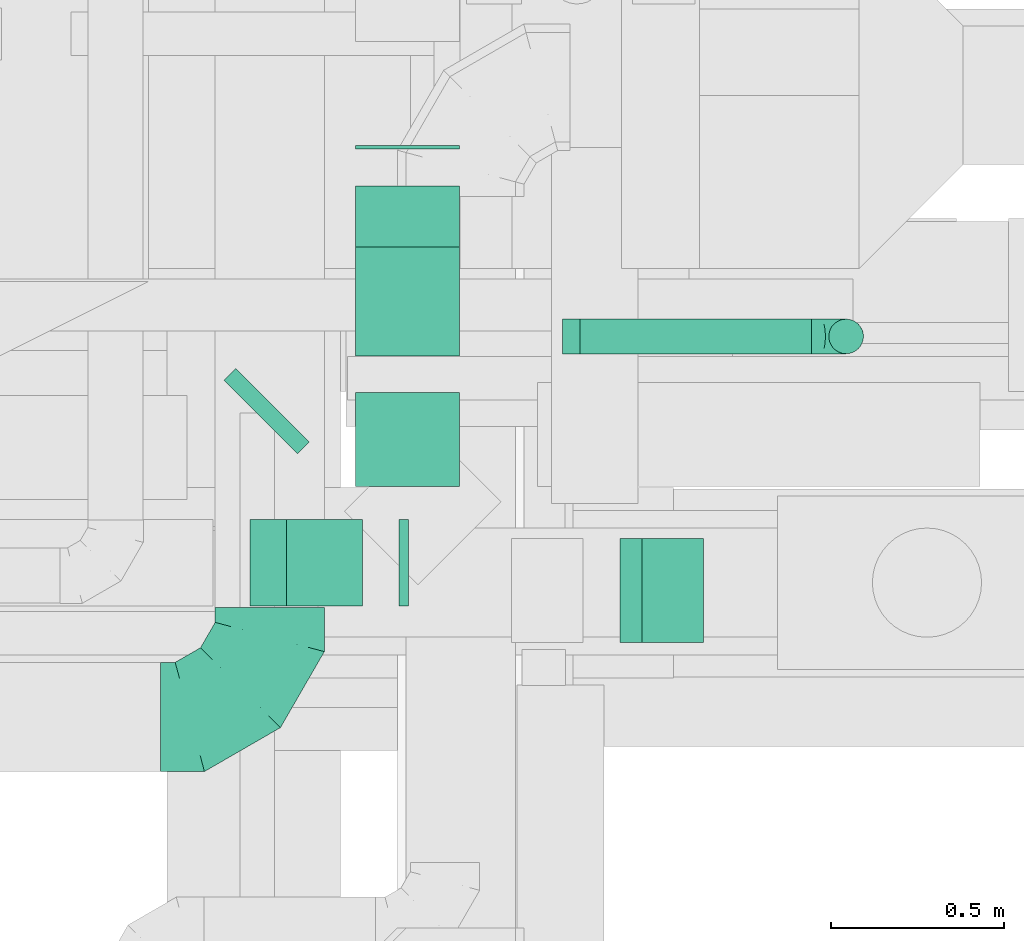
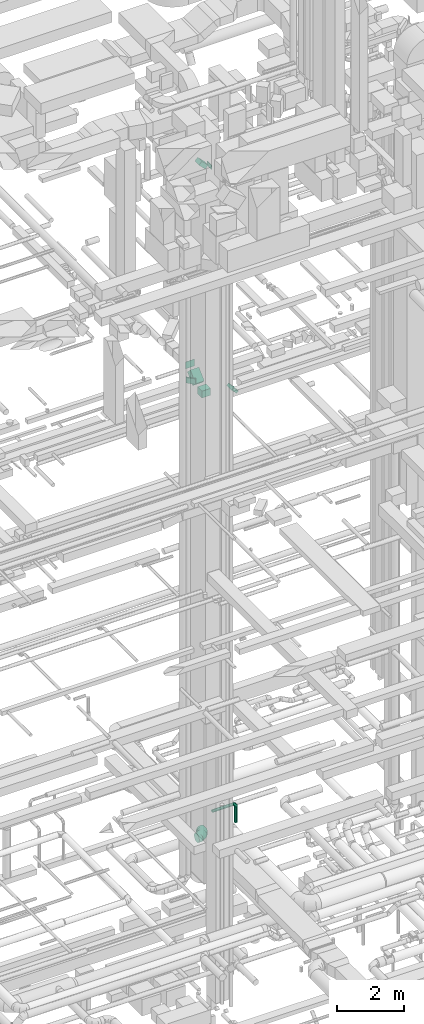
# One storey, part 191 of 337: 9 flow segments, 3 flow fittings.
"""IFC2X3 building model written with IfcOpenShell, lengths in millimetres."""

from ifc_helpers import new_model, entity, si_unit, converted_unit, derived_unit, direction, frame, frame_2d, origin, origin_2d_with_axis, place, context, subcontext, project, spatial, rectangle, circle, extrude, faceted_brep, source, transform, mapped, material, type_object, type_shapes, element, save


model = new_model("IFC2X3")

# Units and contexts
model_context = context("Model", 3, precision=0.01, world=origin(), true_north=direction((6.12303176911189e-17, 1.0)))
body_context = subcontext(model_context, "Body", "Model", "MODEL_VIEW")
ifc_project = project(units=[si_unit("LENGTHUNIT", "METRE", prefix="MILLI"), si_unit("AREAUNIT", "SQUARE_METRE"), si_unit("VOLUMEUNIT", "CUBIC_METRE"), converted_unit("PLANEANGLEUNIT", "DEGREE", entity("IfcRatioMeasure", 0.0174532925199433), si_unit("PLANEANGLEUNIT", "RADIAN"), dimensions=[0, 0, 0, 0, 0, 0, 0]), si_unit("MASSUNIT", "GRAM", prefix="KILO"), derived_unit("MASSDENSITYUNIT", [(si_unit("MASSUNIT", "GRAM", prefix="KILO"), 1), (si_unit("LENGTHUNIT", "METRE"), -3)]), derived_unit("MOMENTOFINERTIAUNIT", [(si_unit("LENGTHUNIT", "METRE"), 4)]), si_unit("TIMEUNIT", "SECOND"), si_unit("FREQUENCYUNIT", "HERTZ"), si_unit("THERMODYNAMICTEMPERATUREUNIT", "DEGREE_CELSIUS"), derived_unit("THERMALTRANSMITTANCEUNIT", [(si_unit("MASSUNIT", "GRAM", prefix="KILO"), 1), (si_unit("THERMODYNAMICTEMPERATUREUNIT", "KELVIN"), -1), (si_unit("TIMEUNIT", "SECOND"), -3)]), derived_unit("VOLUMETRICFLOWRATEUNIT", [(si_unit("LENGTHUNIT", "METRE"), 3), (si_unit("TIMEUNIT", "SECOND"), -1)]), derived_unit("MASSFLOWRATEUNIT", [(si_unit("MASSUNIT", "GRAM", prefix="KILO"), 1), (si_unit("TIMEUNIT", "SECOND"), -1)]), derived_unit("ROTATIONALFREQUENCYUNIT", [(si_unit("TIMEUNIT", "SECOND"), -1)]), si_unit("ELECTRICCURRENTUNIT", "AMPERE"), si_unit("ELECTRICVOLTAGEUNIT", "VOLT"), si_unit("POWERUNIT", "WATT"), si_unit("FORCEUNIT", "NEWTON", prefix="KILO"), si_unit("ILLUMINANCEUNIT", "LUX"), si_unit("LUMINOUSFLUXUNIT", "LUMEN"), si_unit("LUMINOUSINTENSITYUNIT", "CANDELA"), derived_unit("USERDEFINED", [(si_unit("MASSUNIT", "GRAM", prefix="KILO"), -1), (si_unit("LENGTHUNIT", "METRE"), -2), (si_unit("TIMEUNIT", "SECOND"), 3), (si_unit("LUMINOUSFLUXUNIT", "LUMEN"), 1)]), derived_unit("LINEARVELOCITYUNIT", [(si_unit("LENGTHUNIT", "METRE"), 1), (si_unit("TIMEUNIT", "SECOND"), -1)]), si_unit("PRESSUREUNIT", "PASCAL"), derived_unit("USERDEFINED", [(si_unit("LENGTHUNIT", "METRE"), -2), (si_unit("MASSUNIT", "GRAM", prefix="KILO"), 1), (si_unit("TIMEUNIT", "SECOND"), -2)]), derived_unit("LINEARFORCEUNIT", [(si_unit("MASSUNIT", "GRAM", prefix="KILO"), 1), (si_unit("LENGTHUNIT", "METRE"), 1), (si_unit("TIMEUNIT", "SECOND"), -2), (si_unit("LENGTHUNIT", "METRE"), -1)]), derived_unit("PLANARFORCEUNIT", [(si_unit("MASSUNIT", "GRAM", prefix="KILO"), 1), (si_unit("LENGTHUNIT", "METRE"), 1), (si_unit("TIMEUNIT", "SECOND"), -2), (si_unit("LENGTHUNIT", "METRE"), -2)])], contexts=[model_context])

# Site, building, storey
site_placement = place(None, origin())
site = spatial("IfcSite", under=ifc_project, at=site_placement, CompositionType="ELEMENT")
building_placement = place(site_placement, origin())
building = spatial("IfcBuilding", under=site, at=building_placement, CompositionType="ELEMENT")
storey_placement = place(building_placement, origin())
storey = spatial("IfcBuildingStorey", under=building, at=storey_placement, CompositionType="ELEMENT", Elevation=0.0)

# Flow segments
duct_segment_type_1 = type_object("IfcDuctSegmentType", PredefinedType="NOTDEFINED")
flow_segment_1_placement = place(storey_placement, frame((46619.03, 15799.14, 19100.0)))
element("IfcFlowSegment", 1, at=flow_segment_1_placement, inside=storey, type_object=duct_segment_type_1, context=body_context, shape_type="SweptSolid", body=[
    extrude(rectangle(XDim=11.0912703472507, YDim=300.000000000001, at=origin_2d_with_axis()), frame((150.0, 5.55, 0.0), z_axis=(0.0, 0.0, 1.0), x_axis=(0.0, -1.0, 0.0)), (0.0, 0.0, 1.0), 249.999999999999),
])
flow_segment_2_placement = place(storey_placement, frame((46619.03, 15202.38, 18742.16)))
element("IfcFlowSegment", 2, at=flow_segment_2_placement, inside=storey, type_object=duct_segment_type_1, context=body_context, shape_type="SweptSolid", body=[
    extrude(rectangle(XDim=250.0, YDim=300.000000000001, at=frame_2d((0.0, 0.0), x_axis=(0.0, 1.0))), frame((150.0, 88.39, 88.39), z_axis=(0.0, 0.70710678118653, 0.707106781186565), x_axis=(-1.0, 0.0, 0.0)), (0.0, 0.0, 1.0), 443.933982822071),
])
flow_segment_3_placement = place(storey_placement, frame((46619.03, 14825.32, 18625.0)))
element("IfcFlowSegment", 3, at=flow_segment_3_placement, inside=storey, type_object=duct_segment_type_1, context=body_context, shape_type="SweptSolid", body=[
    extrude(rectangle(XDim=270.994590428637, YDim=300.000000000001, at=origin_2d_with_axis()), frame((150.0, 135.5, 0.0), z_axis=(0.0, 0.0, 1.0), x_axis=(0.0, -1.0, 0.0)), (0.0, 0.0, 1.0), 249.999999999999),
])
flow_segment_4_placement = place(storey_placement, frame((47381.9, 14375.32, 18742.16)))
element("IfcFlowSegment", 4, at=flow_segment_4_placement, inside=storey, type_object=duct_segment_type_1, context=body_context, shape_type="SweptSolid", body=[
    extrude(rectangle(XDim=250.000000000009, YDim=90.3806024748539, at=frame_2d((0.0, 0.0), x_axis=(0.0, 1.0))), frame((120.34, 0.0, 120.34), z_axis=(0.0, 1.0, 0.0), x_axis=(0.707106792500133, 0.0, 0.707106769872962)), (0.0, 0.0, 1.0), 300.000000000001),
])
flow_segment_5_placement = place(storey_placement, frame((46238.96, 14920.16, 19125.02)))
element("IfcFlowSegment", 5, at=flow_segment_5_placement, inside=storey, type_object=duct_segment_type_1, context=body_context, shape_type="SweptSolid", body=[
    extrude(rectangle(XDim=48.8373029032234, YDim=300.0, at=origin_2d_with_axis()), frame((123.33, 123.33, 0.0), z_axis=(0.0, 0.0, 1.0), x_axis=(-0.707106781186082, -0.707106781187013, 0.0)), (0.0, 0.0, 1.0), 199.999999999998),
])
flow_segment_6_placement = place(storey_placement, frame((46744.63, 14481.21, 27125.0)))
element("IfcFlowSegment", 6, at=flow_segment_6_placement, inside=storey, type_object=duct_segment_type_1, context=body_context, shape_type="SweptSolid", body=[
    extrude(rectangle(XDim=26.8019484661804, YDim=249.999999999999, at=origin_2d_with_axis()), frame((13.4, 125.0, 0.0), z_axis=(0.0, 0.0, 1.0), x_axis=(-1.0, 0.0, 0.0)), (0.0, 0.0, 1.0), 150.000000000001),
])
flow_segment_7_placement = place(storey_placement, frame((46314.3, 14481.21, 27212.87)))
element("IfcFlowSegment", 7, at=flow_segment_7_placement, inside=storey, type_object=duct_segment_type_1, context=body_context, shape_type="SweptSolid", body=[
    extrude(rectangle(XDim=149.999999999987, YDim=249.999999999999, at=origin_2d_with_axis()), frame((271.23, 125.0, 53.03), z_axis=(-0.707106781186519, 0.0, 0.707106781186576), x_axis=(0.707106781186576, 0.0, 0.707106781186519)), (0.0, 0.0, 1.0), 308.578643762671),
])
duct_segment_type_2 = type_object("IfcDuctSegmentType", PredefinedType="NOTDEFINED")
flow_segment_8_placement = place(storey_placement, frame((47267.09, 15207.12, 3048.4)))
element("IfcFlowSegment", 8, at=flow_segment_8_placement, inside=storey, type_object=duct_segment_type_2, context=body_context, shape_type="SweptSolid", body=[
    extrude(circle(Radius=50.0, at=origin_2d_with_axis()), frame((0.0, 51.6, 51.6), z_axis=(1.0, 0.0, 0.0), x_axis=(0.0, -1.0, 0.0)), (0.0, 0.0, 1.0), 667.237416712188),
])
flow_segment_9_placement = place(storey_placement, frame((47982.74, 15207.12, 2420.0)))
element("IfcFlowSegment", 9, at=flow_segment_9_placement, inside=storey, type_object=duct_segment_type_2, context=body_context, shape_type="SweptSolid", body=[
    extrude(circle(Radius=50.0, at=origin_2d_with_axis()), frame((51.6, 51.6, 0.0), z_axis=(0.0, 0.0, 1.0), x_axis=(0.0, -1.0, 0.0)), (0.0, 0.0, 1.0), 580.000000000009),
])

# Flow fittings
ifc_material = material()
duct_fitting_type_1 = type_object("IfcDuctFittingType", PredefinedType="NOTDEFINED", material=ifc_material)
shared_shape_1 = source(origin(), body_context, "Body", "Brep", [
    faceted_brep([(-100.0, 0.0, -50.0), (-100.0, -12.94, -48.3), (-100.0, -25.0, -43.3), (-100.0, -35.36, -35.36), (-100.0, -43.3, -25.0), (-100.0, -48.3, -12.94), (-100.0, -50.0, 0.0), (-100.0, -48.3, 12.94), (-100.0, -43.3, 25.0), (-100.0, -35.36, 35.36), (-100.0, -25.0, 43.3), (-100.0, -12.94, 48.3), (-100.0, 0.0, 50.0), (-100.0, 12.94, 48.3), (-100.0, 25.0, 43.3), (-100.0, 35.36, 35.36), (-100.0, 43.3, 25.0), (-100.0, 48.3, 12.94), (-100.0, 50.0, 0.0), (-100.0, 48.3, -12.94), (-100.0, 43.3, -25.0), (-100.0, 35.36, -35.36), (-100.0, 25.0, -43.3), (-100.0, 12.94, -48.3), (-76.67, 12.94, 48.3), (-79.9, 25.0, 43.3), (-73.21, 0.0, 50.0), (-82.68, 35.36, 35.36), (-86.15, 48.3, 12.94), (-86.6, 50.0, 0.0), (-84.81, 43.3, 25.0), (-84.81, 43.3, -25.0), (-82.68, 35.36, -35.36), (-86.15, 48.3, -12.94), (-76.67, 12.94, -48.3), (-73.21, 0.0, -50.0), (-79.9, 25.0, -43.3), (-69.74, -12.94, -48.3), (-66.51, -25.0, -43.3), (-63.73, -35.36, -35.36), (-61.6, -43.3, -25.0), (-60.26, -48.3, -12.94), (-59.81, -50.0, 0.0), (-60.26, -48.3, 12.94), (-61.6, -43.3, 25.0), (-63.73, -35.36, 35.36), (-66.51, -25.0, 43.3), (-69.74, -12.94, 48.3), (-36.27, 36.27, 48.3), (-45.1, 45.1, 43.3), (-26.79, 26.79, 50.0), (-52.68, 52.68, 35.36), (-58.49, 58.49, 25.0), (-62.15, 62.15, 12.94), (-63.4, 63.4, 0.0), (-62.15, 62.15, -12.94), (-58.49, 58.49, -25.0), (-52.68, 52.68, -35.36), (-36.27, 36.27, -48.3), (-26.79, 26.79, -50.0), (-45.1, 45.1, -43.3), (-17.32, 17.32, -48.3), (-8.49, 8.49, -43.3), (-0.91, 0.91, -35.36), (4.9, -4.9, -25.0), (8.56, -8.56, -12.94), (9.81, -9.81, 0.0), (8.56, -8.56, 12.94), (4.9, -4.9, 25.0), (-0.91, 0.91, 35.36), (-8.49, 8.49, 43.3), (-17.32, 17.32, 48.3), (-12.94, 76.67, 48.3), (-25.0, 79.9, 43.3), (0.0, 73.21, 50.0), (-35.36, 82.68, 35.36), (-43.3, 84.81, 25.0), (-48.3, 86.15, 12.94), (-50.0, 86.6, 0.0), (-48.3, 86.15, -12.94), (-43.3, 84.81, -25.0), (-35.36, 82.68, -35.36), (-12.94, 76.67, -48.3), (0.0, 73.21, -50.0), (-25.0, 79.9, -43.3), (12.94, 69.74, -48.3), (25.0, 66.51, -43.3), (35.36, 63.73, -35.36), (43.3, 61.6, -25.0), (48.3, 60.26, -12.94), (50.0, 59.81, 0.0), (48.3, 60.26, 12.94), (43.3, 61.6, 25.0), (35.36, 63.73, 35.36), (25.0, 66.51, 43.3), (12.94, 69.74, 48.3), (-12.94, 100.0, -48.3), (-25.0, 100.0, -43.3), (-35.36, 100.0, -35.36), (-43.3, 100.0, -25.0), (-48.3, 100.0, -12.94), (-50.0, 100.0, 0.0), (-48.3, 100.0, 12.94), (-43.3, 100.0, 25.0), (-35.36, 100.0, 35.36), (-25.0, 100.0, 43.3), (-12.94, 100.0, 48.3), (0.0, 100.0, 50.0), (12.94, 100.0, 48.3), (25.0, 100.0, 43.3), (35.36, 100.0, 35.36), (43.3, 100.0, 25.0), (48.3, 100.0, 12.94), (50.0, 100.0, 0.0), (48.3, 100.0, -12.94), (43.3, 100.0, -25.0), (35.36, 100.0, -35.36), (25.0, 100.0, -43.3), (12.94, 100.0, -48.3), (0.0, 100.0, -50.0)], [[[0, 1, 2, 3, 4, 5, 6, 7, 8, 9, 10, 11, 12, 13, 14, 15, 16, 17, 18, 19, 20, 21, 22, 23]], [[24, 25, 14, 13]], [[26, 24, 13, 12]], [[14, 25, 27, 15]], [[28, 29, 18, 17]], [[30, 28, 17, 16]], [[15, 27, 30, 16]], [[20, 31, 32, 21]], [[33, 31, 20, 19]], [[18, 29, 33, 19]], [[34, 35, 0, 23]], [[36, 34, 23, 22]], [[32, 36, 22, 21]], [[2, 1, 37, 38]], [[3, 2, 38, 39]], [[0, 35, 37, 1]], [[5, 4, 40, 41]], [[6, 5, 41, 42]], [[3, 39, 40, 4]], [[6, 42, 43, 7]], [[7, 43, 44, 8]], [[8, 44, 45, 9]], [[10, 46, 47, 11]], [[11, 47, 26, 12]], [[10, 9, 45, 46]], [[48, 49, 25, 24]], [[50, 48, 24, 26]], [[27, 25, 49, 51]], [[52, 53, 28, 30]], [[51, 52, 30, 27]], [[29, 28, 53, 54]], [[55, 56, 31, 33]], [[54, 55, 33, 29]], [[57, 32, 31, 56]], [[58, 59, 35, 34]], [[60, 58, 34, 36]], [[57, 60, 36, 32]], [[37, 35, 59, 61]], [[38, 37, 61, 62]], [[39, 38, 62, 63]], [[41, 40, 64, 65]], [[42, 41, 65, 66]], [[63, 64, 40, 39]], [[43, 42, 66, 67]], [[44, 43, 67, 68]], [[68, 69, 45, 44]], [[46, 45, 69, 70]], [[47, 46, 70, 71]], [[26, 47, 71, 50]], [[72, 73, 49, 48]], [[74, 72, 48, 50]], [[51, 49, 73, 75]], [[76, 77, 53, 52]], [[75, 76, 52, 51]], [[54, 53, 77, 78]], [[79, 80, 56, 55]], [[78, 79, 55, 54]], [[81, 57, 56, 80]], [[82, 83, 59, 58]], [[84, 82, 58, 60]], [[81, 84, 60, 57]], [[61, 59, 83, 85]], [[62, 61, 85, 86]], [[63, 62, 86, 87]], [[65, 64, 88, 89]], [[66, 65, 89, 90]], [[87, 88, 64, 63]], [[67, 66, 90, 91]], [[68, 67, 91, 92]], [[92, 93, 69, 68]], [[70, 69, 93, 94]], [[71, 70, 94, 95]], [[50, 71, 95, 74]], [[96, 97, 98, 99, 100, 101, 102, 103, 104, 105, 106, 107, 108, 109, 110, 111, 112, 113, 114, 115, 116, 117, 118, 119]], [[72, 74, 107, 106]], [[73, 72, 106, 105]], [[75, 73, 105, 104]], [[77, 76, 103, 102]], [[78, 77, 102, 101]], [[75, 104, 103, 76]], [[78, 101, 100, 79]], [[79, 100, 99, 80]], [[80, 99, 98, 81]], [[96, 119, 83, 82]], [[97, 96, 82, 84]], [[84, 81, 98, 97]], [[83, 119, 118, 85]], [[85, 118, 117, 86]], [[86, 117, 116, 87]], [[88, 115, 114, 89]], [[89, 114, 113, 90]], [[87, 116, 115, 88]], [[91, 90, 113, 112]], [[92, 91, 112, 111]], [[93, 92, 111, 110]], [[95, 94, 109, 108]], [[74, 95, 108, 107]], [[110, 109, 94, 93]]]),
])
type_shapes(duct_fitting_type_1, [shared_shape_1])
flow_fitting_1_placement = place(storey_placement, frame((48034.33, 15258.71, 3100.0), z_axis=(0.0, 1.0, 0.0), x_axis=(1.0, 0.0, 0.0)))
element("IfcFlowFitting", 10, at=flow_fitting_1_placement, inside=storey, type_object=duct_fitting_type_1, material=ifc_material, context=body_context, shape_type="MappedRepresentation", body=[
    mapped(shared_shape_1, transform((0.0, 0.0, 0.0), scale=1.0)),
])
duct_fitting_type_2 = type_object("IfcDuctFittingType", PredefinedType="NOTDEFINED", material=ifc_material)
shared_shape_2 = source(origin(), body_context, "Body", "Brep", [
    faceted_brep([(-315.0, 0.0, -157.5), (-315.0, -40.76, -152.13), (-315.0, -78.75, -136.4), (-315.0, -111.37, -111.37), (-315.0, -136.4, -78.75), (-315.0, -152.13, -40.76), (-315.0, -157.5, 0.0), (-315.0, -152.13, 40.76), (-315.0, -136.4, 78.75), (-315.0, -111.37, 111.37), (-315.0, -78.75, 136.4), (-315.0, -40.76, 152.13), (-315.0, 0.0, 157.5), (-315.0, 40.76, 152.13), (-315.0, 78.75, 136.4), (-315.0, 111.37, 111.37), (-315.0, 136.4, 78.75), (-315.0, 152.13, 40.76), (-315.0, 157.5, 0.0), (-315.0, 152.13, -40.76), (-315.0, 136.4, -78.75), (-315.0, 111.37, -111.37), (-315.0, 78.75, -136.4), (-315.0, 40.76, -152.13), (-241.52, 40.76, 152.13), (-251.7, 78.75, 136.4), (-230.6, 0.0, 157.5), (-260.44, 111.37, 111.37), (-271.36, 152.13, 40.76), (-272.8, 157.5, 0.0), (-267.14, 136.4, 78.75), (-267.14, 136.4, -78.75), (-260.44, 111.37, -111.37), (-271.36, 152.13, -40.76), (-241.52, 40.76, -152.13), (-230.6, 0.0, -157.5), (-251.7, 78.75, -136.4), (-219.67, -40.76, -152.13), (-209.5, -78.75, -136.4), (-200.75, -111.37, -111.37), (-194.05, -136.4, -78.75), (-189.83, -152.13, -40.76), (-188.39, -157.5, 0.0), (-189.83, -152.13, 40.76), (-194.05, -136.4, 78.75), (-200.75, -111.37, 111.37), (-209.5, -78.75, 136.4), (-219.67, -40.76, 152.13), (-114.25, 114.25, 152.13), (-142.05, 142.05, 136.4), (-84.4, 84.4, 157.5), (-165.93, 165.93, 111.37), (-184.25, 184.25, 78.75), (-195.77, 195.77, 40.76), (-199.7, 199.7, 0.0), (-195.77, 195.77, -40.76), (-184.25, 184.25, -78.75), (-165.93, 165.93, -111.37), (-114.25, 114.25, -152.13), (-84.4, 84.4, -157.5), (-142.05, 142.05, -136.4), (-54.56, 54.56, -152.13), (-26.75, 26.75, -136.4), (-2.88, 2.88, -111.37), (15.45, -15.45, -78.75), (26.97, -26.97, -40.76), (30.89, -30.89, 0.0), (26.97, -26.97, 40.76), (15.45, -15.45, 78.75), (-2.88, 2.88, 111.37), (-26.75, 26.75, 136.4), (-54.56, 54.56, 152.13), (-40.76, 241.52, 152.13), (-78.75, 251.7, 136.4), (0.0, 230.6, 157.5), (-111.37, 260.44, 111.37), (-136.4, 267.14, 78.75), (-152.13, 271.36, 40.76), (-157.5, 272.8, 0.0), (-152.13, 271.36, -40.76), (-136.4, 267.14, -78.75), (-111.37, 260.44, -111.37), (-40.76, 241.52, -152.13), (0.0, 230.6, -157.5), (-78.75, 251.7, -136.4), (40.76, 219.67, -152.13), (78.75, 209.5, -136.4), (111.37, 200.75, -111.37), (136.4, 194.05, -78.75), (152.13, 189.83, -40.76), (157.5, 188.39, 0.0), (152.13, 189.83, 40.76), (136.4, 194.05, 78.75), (111.37, 200.75, 111.37), (78.75, 209.5, 136.4), (40.76, 219.67, 152.13), (-40.76, 315.0, -152.13), (-78.75, 315.0, -136.4), (-111.37, 315.0, -111.37), (-136.4, 315.0, -78.75), (-152.13, 315.0, -40.76), (-157.5, 315.0, 0.0), (-152.13, 315.0, 40.76), (-136.4, 315.0, 78.75), (-111.37, 315.0, 111.37), (-78.75, 315.0, 136.4), (-40.76, 315.0, 152.13), (0.0, 315.0, 157.5), (40.76, 315.0, 152.13), (78.75, 315.0, 136.4), (111.37, 315.0, 111.37), (136.4, 315.0, 78.75), (152.13, 315.0, 40.76), (157.5, 315.0, 0.0), (152.13, 315.0, -40.76), (136.4, 315.0, -78.75), (111.37, 315.0, -111.37), (78.75, 315.0, -136.4), (40.76, 315.0, -152.13), (0.0, 315.0, -157.5)], [[[0, 1, 2, 3, 4, 5, 6, 7, 8, 9, 10, 11, 12, 13, 14, 15, 16, 17, 18, 19, 20, 21, 22, 23]], [[24, 25, 14, 13]], [[26, 24, 13, 12]], [[14, 25, 27, 15]], [[28, 29, 18, 17]], [[30, 28, 17, 16]], [[15, 27, 30, 16]], [[20, 31, 32, 21]], [[33, 31, 20, 19]], [[18, 29, 33, 19]], [[34, 35, 0, 23]], [[36, 34, 23, 22]], [[32, 36, 22, 21]], [[1, 0, 35, 37]], [[2, 1, 37, 38]], [[38, 39, 3, 2]], [[5, 4, 40, 41]], [[6, 5, 41, 42]], [[39, 40, 4, 3]], [[6, 42, 43, 7]], [[7, 43, 44, 8]], [[8, 44, 45, 9]], [[9, 45, 46, 10]], [[10, 46, 47, 11]], [[26, 12, 11, 47]], [[48, 49, 25, 24]], [[50, 48, 24, 26]], [[27, 25, 49, 51]], [[52, 53, 28, 30]], [[51, 52, 30, 27]], [[29, 28, 53, 54]], [[55, 56, 31, 33]], [[54, 55, 33, 29]], [[32, 31, 56, 57]], [[58, 59, 35, 34]], [[60, 58, 34, 36]], [[57, 60, 36, 32]], [[37, 35, 59, 61]], [[38, 37, 61, 62]], [[39, 38, 62, 63]], [[41, 40, 64, 65]], [[42, 41, 65, 66]], [[63, 64, 40, 39]], [[43, 42, 66, 67]], [[44, 43, 67, 68]], [[68, 69, 45, 44]], [[46, 45, 69, 70]], [[47, 46, 70, 71]], [[26, 47, 71, 50]], [[72, 73, 49, 48]], [[74, 72, 48, 50]], [[51, 49, 73, 75]], [[76, 77, 53, 52]], [[75, 76, 52, 51]], [[54, 53, 77, 78]], [[79, 80, 56, 55]], [[78, 79, 55, 54]], [[57, 56, 80, 81]], [[82, 83, 59, 58]], [[84, 82, 58, 60]], [[81, 84, 60, 57]], [[61, 59, 83, 85]], [[62, 61, 85, 86]], [[63, 62, 86, 87]], [[65, 64, 88, 89]], [[66, 65, 89, 90]], [[87, 88, 64, 63]], [[67, 66, 90, 91]], [[68, 67, 91, 92]], [[92, 93, 69, 68]], [[70, 69, 93, 94]], [[71, 70, 94, 95]], [[50, 71, 95, 74]], [[96, 97, 98, 99, 100, 101, 102, 103, 104, 105, 106, 107, 108, 109, 110, 111, 112, 113, 114, 115, 116, 117, 118, 119]], [[106, 105, 73, 72]], [[107, 106, 72, 74]], [[75, 73, 105, 104]], [[77, 76, 103, 102]], [[78, 77, 102, 101]], [[104, 103, 76, 75]], [[78, 101, 100, 79]], [[79, 100, 99, 80]], [[98, 81, 80, 99]], [[84, 97, 96, 82]], [[82, 96, 119, 83]], [[97, 84, 81, 98]], [[83, 119, 118, 85]], [[85, 118, 117, 86]], [[116, 87, 86, 117]], [[88, 115, 114, 89]], [[89, 114, 113, 90]], [[115, 88, 87, 116]], [[91, 90, 113, 112]], [[92, 91, 112, 111]], [[111, 110, 93, 92]], [[95, 94, 109, 108]], [[74, 95, 108, 107]], [[110, 109, 94, 93]]]),
])
type_shapes(duct_fitting_type_2, [shared_shape_2])
flow_fitting_2_placement = place(storey_placement, frame((46371.59, 14160.95, 3200.0)))
element("IfcFlowFitting", 11, at=flow_fitting_2_placement, inside=storey, type_object=duct_fitting_type_2, material=ifc_material, context=body_context, shape_type="MappedRepresentation", body=[
    mapped(shared_shape_2, transform((0.0, 0.0, 0.0), scale=1.0)),
])
duct_fitting_type_3 = type_object("IfcDuctFittingType", PredefinedType="NOTDEFINED", material=ifc_material)
shared_shape_3 = source(origin(), body_context, "Body", "Brep", [
    faceted_brep([(20.0, 0.0, -50.0), (20.0, 12.94, -48.3), (20.0, 25.0, -43.3), (20.0, 35.36, -35.36), (20.0, 43.3, -25.0), (20.0, 48.3, -12.94), (20.0, 50.0, 0.0), (20.0, 48.3, 12.94), (20.0, 43.3, 25.0), (20.0, 35.36, 35.36), (20.0, 25.0, 43.3), (20.0, 12.94, 48.3), (20.0, 0.0, 50.0), (20.0, -12.94, 48.3), (20.0, -25.0, 43.3), (20.0, -35.36, 35.36), (20.0, -43.3, 25.0), (20.0, -48.3, 12.94), (20.0, -50.0, 0.0), (20.0, -48.3, -12.94), (20.0, -43.3, -25.0), (20.0, -35.36, -35.36), (20.0, -25.0, -43.3), (20.0, -12.94, -48.3), (0.0, 0.0, 50.0), (-31.1, 0.0, 50.0), (-31.1, -12.94, 48.3), (0.0, -12.94, 48.3), (-31.1, -25.0, 43.3), (0.0, -25.0, 43.3), (0.0, -35.36, 35.36), (-31.1, -35.36, 35.36), (0.0, -43.3, 25.0), (-31.1, -43.3, 25.0), (-31.1, -48.3, 12.94), (0.0, -48.3, 12.94), (-31.1, -50.0, 0.0), (0.0, -50.0, 0.0), (-31.1, -48.3, -12.94), (0.0, -48.3, -12.94), (-31.1, -43.3, -25.0), (0.0, -43.3, -25.0), (0.0, -35.36, -35.36), (-31.1, -35.36, -35.36), (0.0, -25.0, -43.3), (-31.1, -25.0, -43.3), (-31.1, -12.94, -48.3), (0.0, -12.94, -48.3), (-31.1, 0.0, -50.0), (0.0, 0.0, -50.0), (-31.1, 12.94, -48.3), (0.0, 12.94, -48.3), (-31.1, 25.0, -43.3), (0.0, 25.0, -43.3), (0.0, 35.36, -35.36), (-31.1, 35.36, -35.36), (0.0, 43.3, -25.0), (-31.1, 43.3, -25.0), (-31.1, 48.3, -12.94), (0.0, 48.3, -12.94), (-31.1, 50.0, 0.0), (0.0, 50.0, 0.0), (-31.1, 48.3, 12.94), (0.0, 48.3, 12.94), (-31.1, 43.3, 25.0), (0.0, 43.3, 25.0), (0.0, 35.36, 35.36), (-31.1, 35.36, 35.36), (0.0, 25.0, 43.3), (-31.1, 25.0, 43.3), (-31.1, 12.94, 48.3), (0.0, 12.94, 48.3)], [[[0, 1, 2, 3, 4, 5, 6, 7, 8, 9, 10, 11, 12, 13, 14, 15, 16, 17, 18, 19, 20, 21, 22, 23]], [[13, 12, 24, 25, 26, 27]], [[14, 13, 27, 26, 28, 29]], [[30, 15, 14, 29, 28, 31]], [[17, 16, 32, 33, 34, 35]], [[18, 17, 35, 34, 36, 37]], [[32, 16, 15, 30, 31, 33]], [[19, 18, 37, 36, 38, 39]], [[20, 19, 39, 38, 40, 41]], [[42, 21, 20, 41, 40, 43]], [[23, 22, 44, 45, 46, 47]], [[0, 23, 47, 46, 48, 49]], [[44, 22, 21, 42, 43, 45]], [[1, 0, 49, 48, 50, 51]], [[2, 1, 51, 50, 52, 53]], [[54, 3, 2, 53, 52, 55]], [[5, 4, 56, 57, 58, 59]], [[6, 5, 59, 58, 60, 61]], [[56, 4, 3, 54, 55, 57]], [[7, 6, 61, 60, 62, 63]], [[8, 7, 63, 62, 64, 65]], [[66, 9, 8, 65, 64, 67]], [[11, 10, 68, 69, 70, 71]], [[12, 11, 71, 70, 25, 24]], [[68, 10, 9, 66, 67, 69]], [[46, 45, 43, 40, 38, 36, 34, 33, 31, 28, 26, 25, 70, 69, 67, 64, 62, 60, 58, 57, 55, 52, 50, 48]]]),
])
type_shapes(duct_fitting_type_3, [shared_shape_3])
flow_fitting_3_placement = place(storey_placement, frame((47247.09, 15258.71, 3100.0), z_axis=(0.0, 0.0, -1.0), x_axis=(1.0, 0.0, 0.0)))
element("IfcFlowFitting", 12, at=flow_fitting_3_placement, inside=storey, type_object=duct_fitting_type_3, material=ifc_material, context=body_context, shape_type="MappedRepresentation", body=[
    mapped(shared_shape_3, transform((0.0, 0.0, 0.0), scale=1.0)),
])

save(model, "model.ifc")
